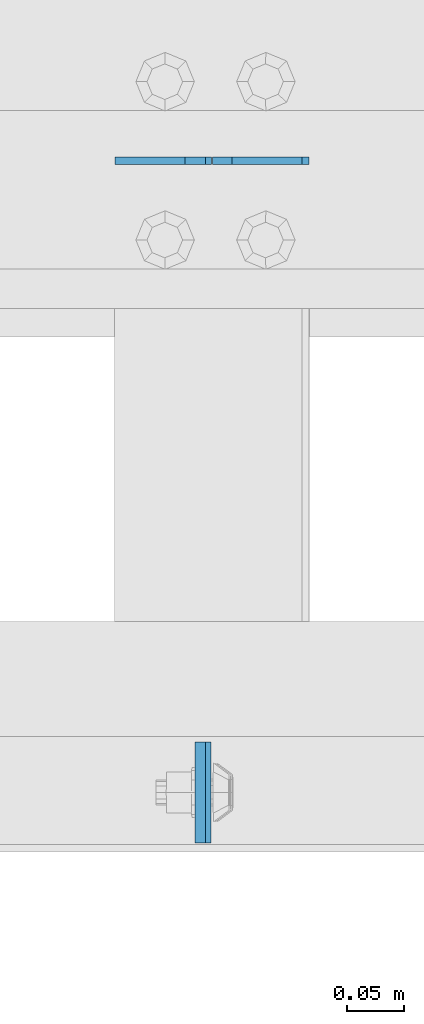
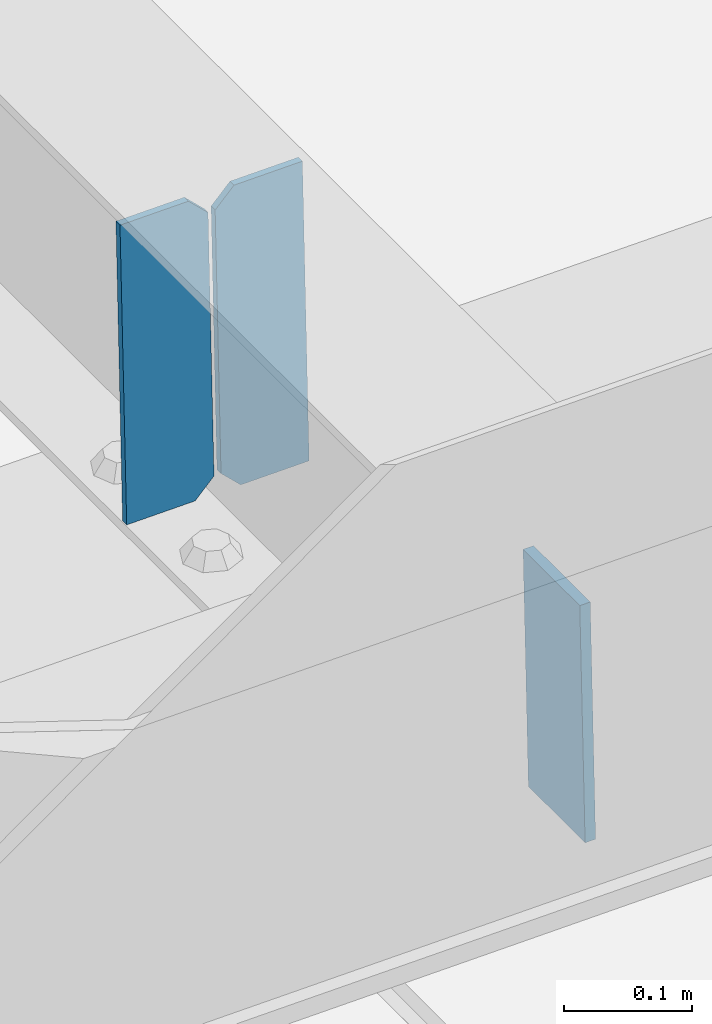
# One storey, part 3027 of 3843: 3 plates, 2 elements without a shape of their own.
"""IFC2X3 building model written with IfcOpenShell, lengths in millimetres."""

from ifc_helpers import new_model, si_unit, frame, origin_with_axes, place, context, subcontext, project, spatial, faceted_brep, material, type_object, element, aggregate, save


model = new_model("IFC2X3")

# Units and contexts
model_context = context("Model", 3, precision=1e-05, world=origin_with_axes())
body_context = subcontext(model_context, "Body", "Model", "MODEL_VIEW")
ifc_project = project(units=[si_unit("LENGTHUNIT", "METRE", prefix="MILLI"), si_unit("AREAUNIT", "SQUARE_METRE"), si_unit("VOLUMEUNIT", "CUBIC_METRE"), si_unit("MASSUNIT", "GRAM", prefix="KILO"), si_unit("TIMEUNIT", "SECOND"), si_unit("PLANEANGLEUNIT", "RADIAN"), si_unit("SOLIDANGLEUNIT", "STERADIAN"), si_unit("THERMODYNAMICTEMPERATUREUNIT", "DEGREE_CELSIUS"), si_unit("LUMINOUSINTENSITYUNIT", "LUMEN")], contexts=[model_context])

# Site, building, storey
site_placement = place(None, origin_with_axes())
site = spatial("IfcSite", under=ifc_project, at=site_placement, CompositionType="ELEMENT")
building_placement = place(site_placement, origin_with_axes())
building = spatial("IfcBuilding", under=site, at=building_placement, Name="Undefined", CompositionType="ELEMENT")
storey_placement = place(building_placement, origin_with_axes())
storey = spatial("IfcBuildingStorey", under=building, at=storey_placement, Name="Undefined", CompositionType="ELEMENT", Elevation=0.0)

# Assembly, plate
assembly_1_placement = place(storey_placement, origin_with_axes())
assembly_1 = element("IfcElementAssembly", 1, at=assembly_1_placement, inside=storey, Name="BEAM", AssemblyPlace="NOTDEFINED", PredefinedType="RIGID_FRAME")
ifc_material = material(Name="STEEL/A572-50")
plate_type_1 = type_object("IfcPlateType", PredefinedType="NOTDEFINED")
plate_1_placement = place(assembly_1_placement, frame((40677.1094385618, 25014.2374850968, 45778.2643568123), z_axis=(0.0, 1.0, 0.0), x_axis=(0.0211520550054438, 0.0, -0.999776270257025)))
plate_1 = element("IfcPlate", 2, at=plate_1_placement, type_object=plate_type_1, material=ifc_material, Name="PLATE", context=body_context, shape_type="Brep", body=[
    faceted_brep([(0.0, -4.76249999999709, 0.0), (0.0, -4.76249999999709, 88.9000015258789), (0.0, 4.76249999999709, 88.9000015258789), (0.0, 4.76249999999709, 0.0), (228.600006102781, -4.7625000004191, 88.9000015257589), (228.600006102781, 4.76249999954598, 88.9000015257443), (228.600006103079, -4.7625000004482, 7.27595761418343e-12), (228.600006103079, 4.76249999954598, -7.27595761418343e-12)], [[[0, 1, 2, 3]], [[1, 4, 5, 2]], [[4, 6, 7, 5]], [[6, 0, 3, 7]], [[5, 7, 3, 2]], [[6, 4, 1, 0]]]),
])
aggregate(assembly_1, [plate_1])

# Assembly, plates
assembly_2_placement = place(storey_placement, origin_with_axes())
assembly_2 = element("IfcElementAssembly", 3, at=assembly_2_placement, inside=storey, Name="BEAM", AssemblyPlace="NOTDEFINED", PredefinedType="RIGID_FRAME")
plate_type_2 = type_object("IfcPlateType", PredefinedType="NOTDEFINED")
plate_2_placement = place(assembly_2_placement, frame((40773.0964782638, 25615.9992866921, 45518.4241907145), z_axis=(-0.0211520975410968, -0.000224554000033095, 0.999776244139214), x_axis=(-0.999776269357106, 4.75099998682526e-06, -0.0211520970075359)))
plate_2 = element("IfcPlate", 4, at=plate_2_placement, type_object=plate_type_2, material=ifc_material, Name="STIFFENER", context=body_context, shape_type="Brep", body=[
    faceted_brep([(0.0, -3.17499999999927, 0.0), (6.83940015733242e-10, -3.17499999996653, 288.924999998613), (6.54836185276508e-10, 3.17500000001746, 288.924999998591), (0.0, 3.17499999999927, 0.0), (61.9125003828667, -3.17499999997744, 288.924999998599), (61.9125003828522, 3.17500000002838, 288.924999998584), (79.3750000013097, -3.17499999997744, 271.462500380039), (79.375000001266, 3.17500000002838, 271.462500380017), (79.375000000713, -3.17499999999927, 17.4624996185448), (79.3750000006694, 3.17500000000291, 17.462499618523), (61.9125003821828, -3.17499999999563, -1.45519152283669e-11), (61.9125003821682, 3.17500000000655, -2.91038304567337e-11)], [[[0, 1, 2, 3]], [[1, 4, 5, 2]], [[4, 6, 7, 5]], [[6, 8, 9, 7]], [[8, 10, 11, 9]], [[10, 0, 3, 11]], [[5, 7, 9, 11, 3, 2]], [[10, 8, 6, 4, 1, 0]]]),
])
plate_3_placement = place(assembly_2_placement, frame((40687.3906575741, 25615.9996939582, 45516.6109271587), z_axis=(-0.0211520975410968, -0.000224554000033095, 0.999776244139214), x_axis=(-0.999776269357106, 4.75099998682526e-06, -0.0211520970075359)))
plate_3 = element("IfcPlate", 5, at=plate_3_placement, type_object=plate_type_2, material=ifc_material, Name="STIFFENER", context=body_context, shape_type="Brep", body=[
    faceted_brep([(5.82076609134674e-11, -3.17499999999927, 17.4624996185667), (6.25732354819775e-10, -3.17499999997744, 271.462500380054), (5.82076609134674e-10, 3.17500000002474, 271.462500380039), (0.0, 3.17500000000655, 17.4624996185521), (17.462499619156, -3.17499999997744, 288.924999998606), (17.4624996191269, 3.17500000002474, 288.924999998591), (79.3750000013242, -3.17500000025029, 288.924999998591), (79.3750000013097, 3.1749999997337, 288.92499999857), (79.3750000006548, -3.17500000026484, -2.18278728425503e-11), (79.3750000006403, 3.17499999969732, -2.91038304567337e-11), (17.4624996184866, -3.17500000000291, 7.27595761418343e-12), (17.462499618443, 3.17500000000291, -7.27595761418343e-12)], [[[0, 1, 2, 3]], [[1, 4, 5, 2]], [[4, 6, 7, 5]], [[6, 8, 9, 7]], [[8, 10, 11, 9]], [[10, 0, 3, 11]], [[5, 7, 9, 11, 3, 2]], [[10, 8, 6, 4, 1, 0]]]),
])
aggregate(assembly_2, [plate_2, plate_3])

save(model, "model.ifc")
